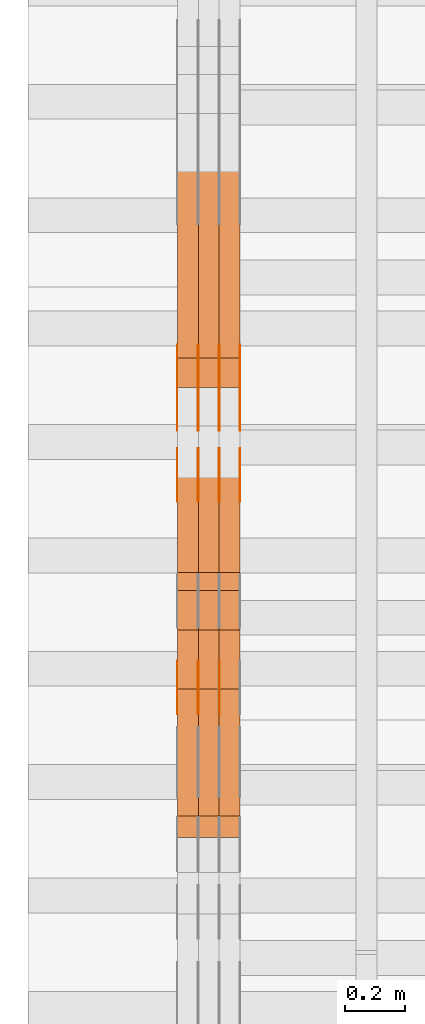
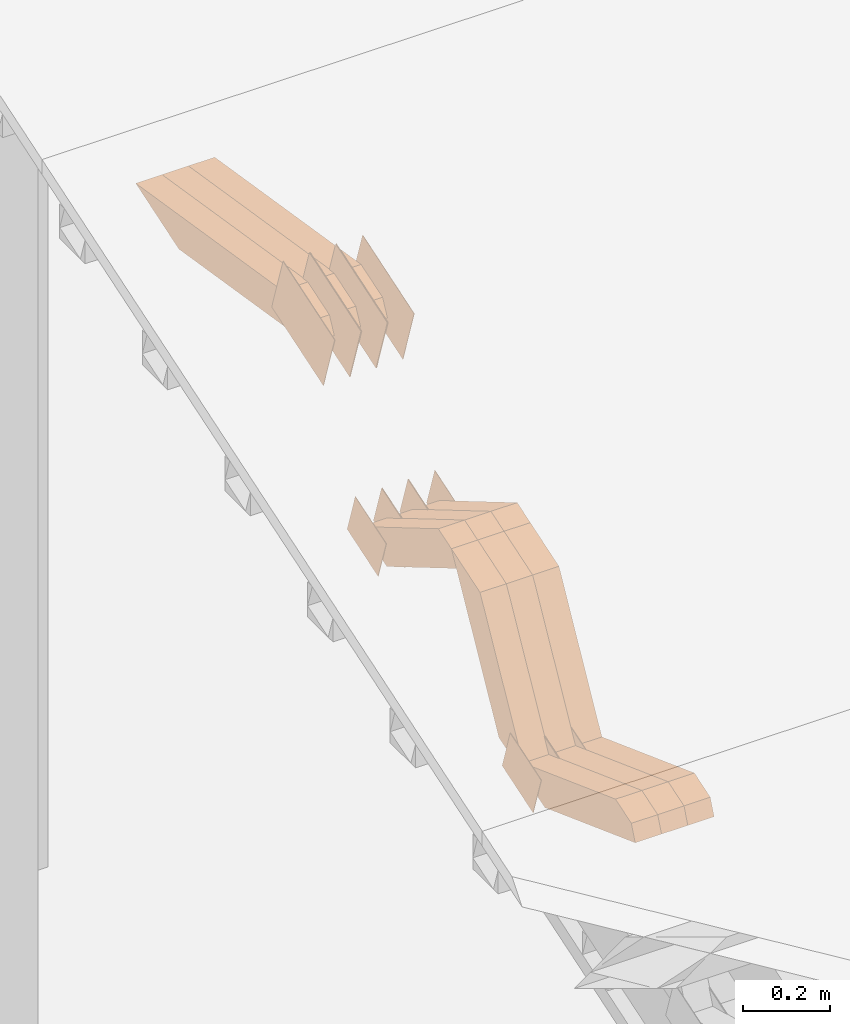
# One storey, part 47 of 385: 28 proxies.
"""IFC2X3 building model written with IfcOpenShell, lengths in millimetres."""

from ifc_helpers import new_model, entity, si_unit, converted_unit, derived_unit, direction, frame, origin, place, context, subcontext, project, spatial, polyline, outline, extrude, source, transform, mapped, material, type_object, type_shapes, element, save


model = new_model("IFC2X3")

# Units and contexts
model_context = context("Model", 3, precision=0.01, world=origin(), true_north=direction((6.12303176911189e-17, 1.0)))
body_context = subcontext(model_context, "Body", "Model", "MODEL_VIEW")
ifc_project = project(units=[si_unit("LENGTHUNIT", "METRE", prefix="MILLI"), si_unit("AREAUNIT", "SQUARE_METRE"), si_unit("VOLUMEUNIT", "CUBIC_METRE"), converted_unit("PLANEANGLEUNIT", "DEGREE", entity("IfcRatioMeasure", 0.0174532925199433), si_unit("PLANEANGLEUNIT", "RADIAN"), dimensions=[0, 0, 0, 0, 0, 0, 0]), si_unit("MASSUNIT", "GRAM", prefix="KILO"), derived_unit("MASSDENSITYUNIT", [(si_unit("MASSUNIT", "GRAM", prefix="KILO"), 1), (si_unit("LENGTHUNIT", "METRE"), -3)]), si_unit("TIMEUNIT", "SECOND"), si_unit("FREQUENCYUNIT", "HERTZ"), si_unit("THERMODYNAMICTEMPERATUREUNIT", "DEGREE_CELSIUS"), derived_unit("THERMALTRANSMITTANCEUNIT", [(si_unit("MASSUNIT", "GRAM", prefix="KILO"), 1), (si_unit("THERMODYNAMICTEMPERATUREUNIT", "KELVIN"), -1), (si_unit("TIMEUNIT", "SECOND"), -3)]), derived_unit("VOLUMETRICFLOWRATEUNIT", [(si_unit("LENGTHUNIT", "METRE"), 3), (si_unit("TIMEUNIT", "SECOND"), -1)]), si_unit("ELECTRICCURRENTUNIT", "AMPERE"), si_unit("ELECTRICVOLTAGEUNIT", "VOLT"), si_unit("POWERUNIT", "WATT"), si_unit("FORCEUNIT", "NEWTON", prefix="KILO"), si_unit("ILLUMINANCEUNIT", "LUX"), si_unit("LUMINOUSFLUXUNIT", "LUMEN"), si_unit("LUMINOUSINTENSITYUNIT", "CANDELA"), derived_unit("USERDEFINED", [(si_unit("MASSUNIT", "GRAM", prefix="KILO"), -1), (si_unit("LENGTHUNIT", "METRE"), -2), (si_unit("TIMEUNIT", "SECOND"), 3), (si_unit("LUMINOUSFLUXUNIT", "LUMEN"), 1)]), derived_unit("LINEARVELOCITYUNIT", [(si_unit("LENGTHUNIT", "METRE"), 1), (si_unit("TIMEUNIT", "SECOND"), -1)]), si_unit("PRESSUREUNIT", "PASCAL"), derived_unit("USERDEFINED", [(si_unit("LENGTHUNIT", "METRE"), -2), (si_unit("MASSUNIT", "GRAM", prefix="KILO"), 1), (si_unit("TIMEUNIT", "SECOND"), -2)])], contexts=[model_context])

# Site, building, storey
site_placement = place(None, origin())
site = spatial("IfcSite", under=ifc_project, at=site_placement, CompositionType="ELEMENT")
building_placement = place(site_placement, origin())
building = spatial("IfcBuilding", under=site, at=building_placement, CompositionType="ELEMENT")
storey_placement = place(building_placement, origin())
storey = spatial("IfcBuildingStorey", under=building, at=storey_placement, Name="Default", CompositionType="ELEMENT", Elevation=0.0)

# Proxies
ifc_material_1 = material(Name="IfcSurfaceStyle #37892")
building_element_proxy_type_1 = type_object("IfcBuildingElementProxyType", PredefinedType="NOTDEFINED", material=ifc_material_1)
shared_shape_1 = source(origin(), body_context, "Body", "SweptSolid", [
    extrude(outline(polyline([(-75.0008041947458, -59.9996998629349), (75.0007893252423, -59.9996998629349), (75.0008041947458, 59.9996998629349), (-75.0007893252423, 59.9996998629349), (-75.0008041947458, -59.9996998629349)])), frame((75.0008041947458, 60.0002282421692, 0.0), z_axis=(0.0, 0.0, 1.0), x_axis=(-1.0, 0.0, 0.0)), (0.0, 0.0, 1.0), 1.3),
])
type_shapes(building_element_proxy_type_1, [shared_shape_1])
proxy_1_placement = place(building_placement, frame((316.299999999986, 9291.048828125, 2194.94482421875), z_axis=(-1.0, 0.0, 0.0), x_axis=(0.0, 0.951056516295124, 0.309016994375039)))
element("IfcBuildingElementProxy", 1, at=proxy_1_placement, inside=storey, type_object=building_element_proxy_type_1, material=ifc_material_1, context=body_context, shape_type="MappedRepresentation", body=[
    mapped(shared_shape_1, transform((0.0, 0.0, 0.0), scale=1.0)),
])
ifc_material_2 = material(Name="IfcSurfaceStyle #37835")
building_element_proxy_type_2 = type_object("IfcBuildingElementProxyType", PredefinedType="NOTDEFINED", material=ifc_material_2)
shared_shape_2 = source(origin(), body_context, "Body", "SweptSolid", [
    extrude(outline(polyline([(-75.0008041947458, -59.9996998629349), (75.0007893252423, -59.9996998629349), (75.0008041947458, 59.9996998629349), (-75.0007893252423, 59.9996998629349), (-75.0008041947458, -59.9996998629349)])), frame((75.0008041947458, 60.0002282421692, 0.0), z_axis=(0.0, 0.0, 1.0), x_axis=(-1.0, 0.0, 0.0)), (0.0, 0.0, 1.0), 1.29999999999999),
])
type_shapes(building_element_proxy_type_2, [shared_shape_2])
proxy_2_placement = place(building_placement, frame((245.0, 9291.048828125, 2194.94482421875), z_axis=(-1.0, 0.0, 0.0), x_axis=(0.0, 0.951056516295124, 0.309016994375039)))
element("IfcBuildingElementProxy", 2, at=proxy_2_placement, inside=storey, type_object=building_element_proxy_type_2, material=ifc_material_2, context=body_context, shape_type="MappedRepresentation", body=[
    mapped(shared_shape_2, transform((0.0, 0.0, 0.0), scale=1.0)),
])
ifc_material_3 = material(Name="IfcSurfaceStyle #37778")
building_element_proxy_type_3 = type_object("IfcBuildingElementProxyType", PredefinedType="NOTDEFINED", material=ifc_material_3)
shared_shape_3 = source(origin(), body_context, "Body", "SweptSolid", [
    extrude(outline(polyline([(-75.0008041947458, -59.9996998629349), (75.0007893252423, -59.9996998629349), (75.0008041947458, 59.9996998629349), (-75.0007893252423, 59.9996998629349), (-75.0008041947458, -59.9996998629349)])), frame((75.0008041947458, 60.0002282421692, 0.0), z_axis=(0.0, 0.0, 1.0), x_axis=(-1.0, 0.0, 0.0)), (0.0, 0.0, 1.0), 1.29999999999999),
])
type_shapes(building_element_proxy_type_3, [shared_shape_3])
proxy_3_placement = place(building_placement, frame((246.299999999986, 9291.048828125, 2194.94482421875), z_axis=(-1.0, 0.0, 0.0), x_axis=(0.0, 0.951056516295124, 0.309016994375039)))
element("IfcBuildingElementProxy", 3, at=proxy_3_placement, inside=storey, type_object=building_element_proxy_type_3, material=ifc_material_3, context=body_context, shape_type="MappedRepresentation", body=[
    mapped(shared_shape_3, transform((0.0, 0.0, 0.0), scale=1.0)),
])
ifc_material_4 = material(Name="IfcSurfaceStyle #37721")
building_element_proxy_type_4 = type_object("IfcBuildingElementProxyType", PredefinedType="NOTDEFINED", material=ifc_material_4)
shared_shape_4 = source(origin(), body_context, "Body", "SweptSolid", [
    extrude(outline(polyline([(-75.0008041947458, -59.9996998629349), (75.0007893252423, -59.9996998629349), (75.0008041947458, 59.9996998629349), (-75.0007893252423, 59.9996998629349), (-75.0008041947458, -59.9996998629349)])), frame((75.0008041947458, 60.0002282421692, 0.0), z_axis=(0.0, 0.0, 1.0), x_axis=(-1.0, 0.0, 0.0)), (0.0, 0.0, 1.0), 1.29999999999999),
])
type_shapes(building_element_proxy_type_4, [shared_shape_4])
proxy_4_placement = place(building_placement, frame((175.0, 9291.048828125, 2194.94482421875), z_axis=(-1.0, 0.0, 0.0), x_axis=(0.0, 0.951056516295124, 0.309016994375039)))
element("IfcBuildingElementProxy", 4, at=proxy_4_placement, inside=storey, type_object=building_element_proxy_type_4, material=ifc_material_4, context=body_context, shape_type="MappedRepresentation", body=[
    mapped(shared_shape_4, transform((0.0, 0.0, 0.0), scale=1.0)),
])
ifc_material_5 = material(Name="IfcSurfaceStyle #37664")
building_element_proxy_type_5 = type_object("IfcBuildingElementProxyType", PredefinedType="NOTDEFINED", material=ifc_material_5)
shared_shape_5 = source(origin(), body_context, "Body", "SweptSolid", [
    extrude(outline(polyline([(-124.999432723313, -83.9999457831645), (125.000177551971, -83.9999457831645), (124.999395001513, 83.9999457831646), (-125.000139830171, 83.9999457831645), (-124.999432723313, -83.9999457831645)])), frame((125.000177551971, 84.0001194377192, 0.0), z_axis=(0.0, 0.0, 1.0), x_axis=(-1.0, 0.0, 0.0)), (0.0, 0.0, 1.0), 1.3),
])
type_shapes(building_element_proxy_type_5, [shared_shape_5])
proxy_5_placement = place(building_placement, frame((386.299999999986, 10242.0968435406, 2855.88278137571), z_axis=(-1.0, 0.0, 0.0), x_axis=(0.0, 0.951056516295154, 0.309016994374948)))
element("IfcBuildingElementProxy", 5, at=proxy_5_placement, inside=storey, type_object=building_element_proxy_type_5, material=ifc_material_5, context=body_context, shape_type="MappedRepresentation", body=[
    mapped(shared_shape_5, transform((0.0, 0.0, 0.0), scale=1.0)),
])
ifc_material_6 = material(Name="IfcSurfaceStyle #37607")
building_element_proxy_type_6 = type_object("IfcBuildingElementProxyType", PredefinedType="NOTDEFINED", material=ifc_material_6)
shared_shape_6 = source(origin(), body_context, "Body", "SweptSolid", [
    extrude(outline(polyline([(-124.999432723313, -83.9999457831645), (125.000177551971, -83.9999457831645), (124.999395001513, 83.9999457831646), (-125.000139830171, 83.9999457831645), (-124.999432723313, -83.9999457831645)])), frame((125.000177551971, 84.0001194377192, 0.0), z_axis=(0.0, 0.0, 1.0), x_axis=(-1.0, 0.0, 0.0)), (0.0, 0.0, 1.0), 1.3),
])
type_shapes(building_element_proxy_type_6, [shared_shape_6])
proxy_6_placement = place(building_placement, frame((315.0, 10242.0968435406, 2855.88278137571), z_axis=(-1.0, 0.0, 0.0), x_axis=(0.0, 0.951056516295154, 0.309016994374948)))
element("IfcBuildingElementProxy", 6, at=proxy_6_placement, inside=storey, type_object=building_element_proxy_type_6, material=ifc_material_6, context=body_context, shape_type="MappedRepresentation", body=[
    mapped(shared_shape_6, transform((0.0, 0.0, 0.0), scale=1.0)),
])
ifc_material_7 = material(Name="IfcSurfaceStyle #37550")
building_element_proxy_type_7 = type_object("IfcBuildingElementProxyType", PredefinedType="NOTDEFINED", material=ifc_material_7)
shared_shape_7 = source(origin(), body_context, "Body", "SweptSolid", [
    extrude(outline(polyline([(-124.999432723313, -83.9999457831645), (125.000177551971, -83.9999457831645), (124.999395001513, 83.9999457831646), (-125.000139830171, 83.9999457831645), (-124.999432723313, -83.9999457831645)])), frame((125.000177551971, 84.0001194377192, 0.0), z_axis=(0.0, 0.0, 1.0), x_axis=(-1.0, 0.0, 0.0)), (0.0, 0.0, 1.0), 1.3),
])
type_shapes(building_element_proxy_type_7, [shared_shape_7])
proxy_7_placement = place(building_placement, frame((316.299999999986, 10242.0968435406, 2855.88278137571), z_axis=(-1.0, 0.0, 0.0), x_axis=(0.0, 0.951056516295154, 0.309016994374948)))
element("IfcBuildingElementProxy", 7, at=proxy_7_placement, inside=storey, type_object=building_element_proxy_type_7, material=ifc_material_7, context=body_context, shape_type="MappedRepresentation", body=[
    mapped(shared_shape_7, transform((0.0, 0.0, 0.0), scale=1.0)),
])
ifc_material_8 = material(Name="IfcSurfaceStyle #37493")
building_element_proxy_type_8 = type_object("IfcBuildingElementProxyType", PredefinedType="NOTDEFINED", material=ifc_material_8)
shared_shape_8 = source(origin(), body_context, "Body", "SweptSolid", [
    extrude(outline(polyline([(-124.999432723313, -83.9999457831645), (125.000177551971, -83.9999457831645), (124.999395001513, 83.9999457831646), (-125.000139830171, 83.9999457831645), (-124.999432723313, -83.9999457831645)])), frame((125.000177551971, 84.0001194377192, 0.0), z_axis=(0.0, 0.0, 1.0), x_axis=(-1.0, 0.0, 0.0)), (0.0, 0.0, 1.0), 1.29999999999998),
])
type_shapes(building_element_proxy_type_8, [shared_shape_8])
proxy_8_placement = place(building_placement, frame((245.0, 10242.0968435406, 2855.88278137571), z_axis=(-1.0, 0.0, 0.0), x_axis=(0.0, 0.951056516295154, 0.309016994374948)))
element("IfcBuildingElementProxy", 8, at=proxy_8_placement, inside=storey, type_object=building_element_proxy_type_8, material=ifc_material_8, context=body_context, shape_type="MappedRepresentation", body=[
    mapped(shared_shape_8, transform((0.0, 0.0, 0.0), scale=1.0)),
])
ifc_material_9 = material(Name="IfcSurfaceStyle #37436")
building_element_proxy_type_9 = type_object("IfcBuildingElementProxyType", PredefinedType="NOTDEFINED", material=ifc_material_9)
shared_shape_9 = source(origin(), body_context, "Body", "SweptSolid", [
    extrude(outline(polyline([(-124.999432723313, -83.9999457831645), (125.000177551971, -83.9999457831645), (124.999395001513, 83.9999457831646), (-125.000139830171, 83.9999457831645), (-124.999432723313, -83.9999457831645)])), frame((125.000177551971, 84.0001194377192, 0.0), z_axis=(0.0, 0.0, 1.0), x_axis=(-1.0, 0.0, 0.0)), (0.0, 0.0, 1.0), 1.29999999999998),
])
type_shapes(building_element_proxy_type_9, [shared_shape_9])
proxy_9_placement = place(building_placement, frame((246.299999999986, 10242.0968435406, 2855.88278137571), z_axis=(-1.0, 0.0, 0.0), x_axis=(0.0, 0.951056516295154, 0.309016994374948)))
element("IfcBuildingElementProxy", 9, at=proxy_9_placement, inside=storey, type_object=building_element_proxy_type_9, material=ifc_material_9, context=body_context, shape_type="MappedRepresentation", body=[
    mapped(shared_shape_9, transform((0.0, 0.0, 0.0), scale=1.0)),
])
ifc_material_10 = material(Name="IfcSurfaceStyle #37379")
building_element_proxy_type_10 = type_object("IfcBuildingElementProxyType", PredefinedType="NOTDEFINED", material=ifc_material_10)
shared_shape_10 = source(origin(), body_context, "Body", "SweptSolid", [
    extrude(outline(polyline([(-124.999432723313, -83.9999457831645), (125.000177551971, -83.9999457831645), (124.999395001513, 83.9999457831646), (-125.000139830171, 83.9999457831645), (-124.999432723313, -83.9999457831645)])), frame((125.000177551971, 84.0001194377192, 0.0), z_axis=(0.0, 0.0, 1.0), x_axis=(-1.0, 0.0, 0.0)), (0.0, 0.0, 1.0), 1.29999999999998),
])
type_shapes(building_element_proxy_type_10, [shared_shape_10])
proxy_10_placement = place(building_placement, frame((175.0, 10242.0968435406, 2855.88278137571), z_axis=(-1.0, 0.0, 0.0), x_axis=(0.0, 0.951056516295154, 0.309016994374948)))
element("IfcBuildingElementProxy", 10, at=proxy_10_placement, inside=storey, type_object=building_element_proxy_type_10, material=ifc_material_10, context=body_context, shape_type="MappedRepresentation", body=[
    mapped(shared_shape_10, transform((0.0, 0.0, 0.0), scale=1.0)),
])
ifc_material_11 = material(Name="IfcSurfaceStyle #35954")
building_element_proxy_type_11 = type_object("IfcBuildingElementProxyType", PredefinedType="NOTDEFINED", material=ifc_material_11)
shared_shape_11 = source(origin(), body_context, "Body", "SweptSolid", [
    extrude(outline(polyline([(-74.9998754286189, -60.0000016373433), (74.9998605591118, -60.0000016373433), (74.9998754286189, 60.0000016373433), (-74.9998605591118, 60.0000016373433), (-74.9998754286189, -60.0000016373433)])), frame((74.9999131819004, 60.0000016373433, 0.0), z_axis=(0.0, 0.0, 1.0), x_axis=(-1.0, 0.0, 0.0)), (0.0, 0.0, 1.0), 1.3),
])
type_shapes(building_element_proxy_type_11, [shared_shape_11])
proxy_11_placement = place(building_placement, frame((386.299999999986, 10004.8612689908, 2426.87628052724), z_axis=(-1.0, 0.0, 0.0), x_axis=(0.0, 0.951056516295124, 0.309016994375039)))
element("IfcBuildingElementProxy", 11, at=proxy_11_placement, inside=storey, type_object=building_element_proxy_type_11, material=ifc_material_11, context=body_context, shape_type="MappedRepresentation", body=[
    mapped(shared_shape_11, transform((0.0, 0.0, 0.0), scale=1.0)),
])
ifc_material_12 = material(Name="IfcSurfaceStyle #35897")
building_element_proxy_type_12 = type_object("IfcBuildingElementProxyType", PredefinedType="NOTDEFINED", material=ifc_material_12)
shared_shape_12 = source(origin(), body_context, "Body", "SweptSolid", [
    extrude(outline(polyline([(-74.9998754286189, -60.0000016373433), (74.9998605591118, -60.0000016373433), (74.9998754286189, 60.0000016373433), (-74.9998605591118, 60.0000016373433), (-74.9998754286189, -60.0000016373433)])), frame((74.9999131819004, 60.0000016373433, 0.0), z_axis=(0.0, 0.0, 1.0), x_axis=(-1.0, 0.0, 0.0)), (0.0, 0.0, 1.0), 1.3),
])
type_shapes(building_element_proxy_type_12, [shared_shape_12])
proxy_12_placement = place(building_placement, frame((315.0, 10004.8612689908, 2426.87628052724), z_axis=(-1.0, 0.0, 0.0), x_axis=(0.0, 0.951056516295124, 0.309016994375039)))
element("IfcBuildingElementProxy", 12, at=proxy_12_placement, inside=storey, type_object=building_element_proxy_type_12, material=ifc_material_12, context=body_context, shape_type="MappedRepresentation", body=[
    mapped(shared_shape_12, transform((0.0, 0.0, 0.0), scale=1.0)),
])
ifc_material_13 = material(Name="IfcSurfaceStyle #35840")
building_element_proxy_type_13 = type_object("IfcBuildingElementProxyType", PredefinedType="NOTDEFINED", material=ifc_material_13)
shared_shape_13 = source(origin(), body_context, "Body", "SweptSolid", [
    extrude(outline(polyline([(-74.9998754286189, -60.0000016373433), (74.9998605591118, -60.0000016373433), (74.9998754286189, 60.0000016373433), (-74.9998605591118, 60.0000016373433), (-74.9998754286189, -60.0000016373433)])), frame((74.9999131819004, 60.0000016373433, 0.0), z_axis=(0.0, 0.0, 1.0), x_axis=(-1.0, 0.0, 0.0)), (0.0, 0.0, 1.0), 1.3),
])
type_shapes(building_element_proxy_type_13, [shared_shape_13])
proxy_13_placement = place(building_placement, frame((316.299999999986, 10004.8612689908, 2426.87628052724), z_axis=(-1.0, 0.0, 0.0), x_axis=(0.0, 0.951056516295124, 0.309016994375039)))
element("IfcBuildingElementProxy", 13, at=proxy_13_placement, inside=storey, type_object=building_element_proxy_type_13, material=ifc_material_13, context=body_context, shape_type="MappedRepresentation", body=[
    mapped(shared_shape_13, transform((0.0, 0.0, 0.0), scale=1.0)),
])
ifc_material_14 = material(Name="IfcSurfaceStyle #35783")
building_element_proxy_type_14 = type_object("IfcBuildingElementProxyType", PredefinedType="NOTDEFINED", material=ifc_material_14)
shared_shape_14 = source(origin(), body_context, "Body", "SweptSolid", [
    extrude(outline(polyline([(-74.9998754286189, -60.0000016373433), (74.9998605591118, -60.0000016373433), (74.9998754286189, 60.0000016373433), (-74.9998605591118, 60.0000016373433), (-74.9998754286189, -60.0000016373433)])), frame((74.9999131819004, 60.0000016373433, 0.0), z_axis=(0.0, 0.0, 1.0), x_axis=(-1.0, 0.0, 0.0)), (0.0, 0.0, 1.0), 1.29999999999999),
])
type_shapes(building_element_proxy_type_14, [shared_shape_14])
proxy_14_placement = place(building_placement, frame((245.0, 10004.8612689908, 2426.87628052724), z_axis=(-1.0, 0.0, 0.0), x_axis=(0.0, 0.951056516295124, 0.309016994375039)))
element("IfcBuildingElementProxy", 14, at=proxy_14_placement, inside=storey, type_object=building_element_proxy_type_14, material=ifc_material_14, context=body_context, shape_type="MappedRepresentation", body=[
    mapped(shared_shape_14, transform((0.0, 0.0, 0.0), scale=1.0)),
])
ifc_material_15 = material(Name="IfcSurfaceStyle #35726")
building_element_proxy_type_15 = type_object("IfcBuildingElementProxyType", PredefinedType="NOTDEFINED", material=ifc_material_15)
shared_shape_15 = source(origin(), body_context, "Body", "SweptSolid", [
    extrude(outline(polyline([(-74.9998754286189, -60.0000016373433), (74.9998605591118, -60.0000016373433), (74.9998754286189, 60.0000016373433), (-74.9998605591118, 60.0000016373433), (-74.9998754286189, -60.0000016373433)])), frame((74.9999131819004, 60.0000016373433, 0.0), z_axis=(0.0, 0.0, 1.0), x_axis=(-1.0, 0.0, 0.0)), (0.0, 0.0, 1.0), 1.29999999999999),
])
type_shapes(building_element_proxy_type_15, [shared_shape_15])
proxy_15_placement = place(building_placement, frame((246.299999999986, 10004.8612689908, 2426.87628052724), z_axis=(-1.0, 0.0, 0.0), x_axis=(0.0, 0.951056516295124, 0.309016994375039)))
element("IfcBuildingElementProxy", 15, at=proxy_15_placement, inside=storey, type_object=building_element_proxy_type_15, material=ifc_material_15, context=body_context, shape_type="MappedRepresentation", body=[
    mapped(shared_shape_15, transform((0.0, 0.0, 0.0), scale=1.0)),
])
ifc_material_16 = material(Name="IfcSurfaceStyle #35669")
building_element_proxy_type_16 = type_object("IfcBuildingElementProxyType", PredefinedType="NOTDEFINED", material=ifc_material_16)
shared_shape_16 = source(origin(), body_context, "Body", "SweptSolid", [
    extrude(outline(polyline([(-74.9998754286189, -60.0000016373433), (74.9998605591118, -60.0000016373433), (74.9998754286189, 60.0000016373433), (-74.9998605591118, 60.0000016373433), (-74.9998754286189, -60.0000016373433)])), frame((74.9999131819004, 60.0000016373433, 0.0), z_axis=(0.0, 0.0, 1.0), x_axis=(-1.0, 0.0, 0.0)), (0.0, 0.0, 1.0), 1.29999999999999),
])
type_shapes(building_element_proxy_type_16, [shared_shape_16])
proxy_16_placement = place(building_placement, frame((175.0, 10004.8612689908, 2426.87628052724), z_axis=(-1.0, 0.0, 0.0), x_axis=(0.0, 0.951056516295124, 0.309016994375039)))
element("IfcBuildingElementProxy", 16, at=proxy_16_placement, inside=storey, type_object=building_element_proxy_type_16, material=ifc_material_16, context=body_context, shape_type="MappedRepresentation", body=[
    mapped(shared_shape_16, transform((0.0, 0.0, 0.0), scale=1.0)),
])
ifc_material_17 = material(Name="IfcSurfaceStyle #15632")
building_element_proxy_type_17 = type_object("IfcBuildingElementProxyType", Name="T1-W5 15630", PredefinedType="NOTDEFINED", material=ifc_material_17)
shared_shape_17 = source(origin(), body_context, "Body", "SweptSolid", [
    extrude(outline(polyline([(-301.214270081322, -47.5000783565111), (303.980395954293, -47.5000783565111), (288.664123931657, 0.000197935560590153), (195.704076557203, 47.4999793887309), (-487.134326361831, 47.4999793887309), (-301.214270081322, -47.5000783565111)])), frame((303.980395954293, 47.5001815410909, 0.0), z_axis=(0.0, 0.0, 1.0), x_axis=(-1.0, 0.0, 0.0)), (0.0, 0.0, 1.0), 70.0),
])
type_shapes(building_element_proxy_type_17, [shared_shape_17])
proxy_17_placement = place(building_placement, frame((385.0, 10379.2051671398, 2863.91176079486), z_axis=(-1.0, 0.0, 0.0), x_axis=(0.0, 0.987508363398486, -0.1575665961365)))
element("IfcBuildingElementProxy", 17, at=proxy_17_placement, inside=storey, type_object=building_element_proxy_type_17, material=ifc_material_17, Name="T1-W5", context=body_context, shape_type="MappedRepresentation", body=[
    mapped(shared_shape_17, transform((0.0, 0.0, 0.0), scale=1.0)),
])
ifc_material_18 = material(Name="IfcSurfaceStyle #15566")
building_element_proxy_type_18 = type_object("IfcBuildingElementProxyType", Name="T1-W5 15564", PredefinedType="NOTDEFINED", material=ifc_material_18)
shared_shape_18 = source(origin(), body_context, "Body", "SweptSolid", [
    extrude(outline(polyline([(-301.214270081322, -47.5000783565111), (303.980395954293, -47.5000783565111), (288.664123931657, 0.000197935560590153), (195.704076557203, 47.4999793887309), (-487.134326361831, 47.4999793887309), (-301.214270081322, -47.5000783565111)])), frame((303.980395954293, 47.5001815410909, 0.0), z_axis=(0.0, 0.0, 1.0), x_axis=(-1.0, 0.0, 0.0)), (0.0, 0.0, 1.0), 70.0),
])
type_shapes(building_element_proxy_type_18, [shared_shape_18])
proxy_18_placement = place(building_placement, frame((315.0, 10379.2051671398, 2863.91176079486), z_axis=(-1.0, 0.0, 0.0), x_axis=(0.0, 0.987508363398486, -0.1575665961365)))
element("IfcBuildingElementProxy", 18, at=proxy_18_placement, inside=storey, type_object=building_element_proxy_type_18, material=ifc_material_18, Name="T1-W5", context=body_context, shape_type="MappedRepresentation", body=[
    mapped(shared_shape_18, transform((0.0, 0.0, 0.0), scale=1.0)),
])
ifc_material_19 = material(Name="IfcSurfaceStyle #15500")
building_element_proxy_type_19 = type_object("IfcBuildingElementProxyType", Name="T1-W5 15498", PredefinedType="NOTDEFINED", material=ifc_material_19)
shared_shape_19 = source(origin(), body_context, "Body", "SweptSolid", [
    extrude(outline(polyline([(-301.214270081322, -47.5000783565111), (303.980395954293, -47.5000783565111), (288.664123931657, 0.000197935560590153), (195.704076557203, 47.4999793887309), (-487.134326361831, 47.4999793887309), (-301.214270081322, -47.5000783565111)])), frame((303.980395954293, 47.5001815410909, 0.0), z_axis=(0.0, 0.0, 1.0), x_axis=(-1.0, 0.0, 0.0)), (0.0, 0.0, 1.0), 70.0),
])
type_shapes(building_element_proxy_type_19, [shared_shape_19])
proxy_19_placement = place(building_placement, frame((245.0, 10379.2051671398, 2863.91176079486), z_axis=(-1.0, 0.0, 0.0), x_axis=(0.0, 0.987508363398486, -0.1575665961365)))
element("IfcBuildingElementProxy", 19, at=proxy_19_placement, inside=storey, type_object=building_element_proxy_type_19, material=ifc_material_19, Name="T1-W5", context=body_context, shape_type="MappedRepresentation", body=[
    mapped(shared_shape_19, transform((0.0, 0.0, 0.0), scale=1.0)),
])
ifc_material_20 = material(Name="IfcSurfaceStyle #14840")
building_element_proxy_type_20 = type_object("IfcBuildingElementProxyType", Name="T1-W43 14838", PredefinedType="NOTDEFINED", material=ifc_material_20)
shared_shape_20 = source(origin(), body_context, "Body", "SweptSolid", [
    extrude(outline(polyline([(-198.159905426436, -47.4999961988362), (173.155878681738, -47.4999961988362), (174.585865234707, -0.00038778214839239), (132.582704932703, 47.5001900899104), (-282.164543422712, 47.5001900899104), (-198.159905426436, -47.4999961988362)])), frame((174.585865234707, 47.5001900899104, 0.0), z_axis=(0.0, 0.0, 1.0), x_axis=(-1.0, 0.0, 0.0)), (0.0, 0.0, 1.0), 70.0),
])
type_shapes(building_element_proxy_type_20, [shared_shape_20])
proxy_20_placement = place(building_placement, frame((385.0, 9730.71877771152, 2634.4881681647), z_axis=(-1.0, 0.0, 0.0), x_axis=(0.0, 0.861495156633645, -0.507765787639115)))
element("IfcBuildingElementProxy", 20, at=proxy_20_placement, inside=storey, type_object=building_element_proxy_type_20, material=ifc_material_20, Name="T1-W43", context=body_context, shape_type="MappedRepresentation", body=[
    mapped(shared_shape_20, transform((0.0, 0.0, 0.0), scale=1.0)),
])
ifc_material_21 = material(Name="IfcSurfaceStyle #14774")
building_element_proxy_type_21 = type_object("IfcBuildingElementProxyType", Name="T1-W43 14772", PredefinedType="NOTDEFINED", material=ifc_material_21)
shared_shape_21 = source(origin(), body_context, "Body", "SweptSolid", [
    extrude(outline(polyline([(-198.159905426436, -47.4999961988362), (173.155878681738, -47.4999961988362), (174.585865234707, -0.00038778214839239), (132.582704932703, 47.5001900899104), (-282.164543422712, 47.5001900899104), (-198.159905426436, -47.4999961988362)])), frame((174.585865234707, 47.5001900899104, 0.0), z_axis=(0.0, 0.0, 1.0), x_axis=(-1.0, 0.0, 0.0)), (0.0, 0.0, 1.0), 70.0),
])
type_shapes(building_element_proxy_type_21, [shared_shape_21])
proxy_21_placement = place(building_placement, frame((315.0, 9730.71877771152, 2634.4881681647), z_axis=(-1.0, 0.0, 0.0), x_axis=(0.0, 0.861495156633645, -0.507765787639115)))
element("IfcBuildingElementProxy", 21, at=proxy_21_placement, inside=storey, type_object=building_element_proxy_type_21, material=ifc_material_21, Name="T1-W43", context=body_context, shape_type="MappedRepresentation", body=[
    mapped(shared_shape_21, transform((0.0, 0.0, 0.0), scale=1.0)),
])
ifc_material_22 = material(Name="IfcSurfaceStyle #14708")
building_element_proxy_type_22 = type_object("IfcBuildingElementProxyType", Name="T1-W43 14706", PredefinedType="NOTDEFINED", material=ifc_material_22)
shared_shape_22 = source(origin(), body_context, "Body", "SweptSolid", [
    extrude(outline(polyline([(-198.159905426436, -47.4999961988362), (173.155878681738, -47.4999961988362), (174.585865234707, -0.00038778214839239), (132.582704932703, 47.5001900899104), (-282.164543422712, 47.5001900899104), (-198.159905426436, -47.4999961988362)])), frame((174.585865234707, 47.5001900899104, 0.0), z_axis=(0.0, 0.0, 1.0), x_axis=(-1.0, 0.0, 0.0)), (0.0, 0.0, 1.0), 70.0),
])
type_shapes(building_element_proxy_type_22, [shared_shape_22])
proxy_22_placement = place(building_placement, frame((245.0, 9730.71877771152, 2634.4881681647), z_axis=(-1.0, 0.0, 0.0), x_axis=(0.0, 0.861495156633645, -0.507765787639115)))
element("IfcBuildingElementProxy", 22, at=proxy_22_placement, inside=storey, type_object=building_element_proxy_type_22, material=ifc_material_22, Name="T1-W43", context=body_context, shape_type="MappedRepresentation", body=[
    mapped(shared_shape_22, transform((0.0, 0.0, 0.0), scale=1.0)),
])
ifc_material_23 = material(Name="IfcSurfaceStyle #14444")
building_element_proxy_type_23 = type_object("IfcBuildingElementProxyType", Name="T1-W33 14442", PredefinedType="NOTDEFINED", material=ifc_material_23)
shared_shape_23 = source(origin(), body_context, "Body", "SweptSolid", [
    extrude(outline(polyline([(-314.173070820175, -47.4997758466969), (139.635944117881, -47.4997758466969), (190.204920608233, 0.000348187720347082), (197.369205310989, 47.5001702328475), (-213.036999216928, 47.4990332728259), (-314.173070820175, -47.4997758466969)])), frame((197.369205310989, 47.5001702328475, 0.0), z_axis=(0.0, 0.0, 1.0), x_axis=(-1.0, 0.0, 0.0)), (0.0, 0.0, 1.0), 70.0),
])
type_shapes(building_element_proxy_type_23, [shared_shape_23])
proxy_23_placement = place(building_placement, frame((385.0, 9376.96875, 2191.01977539063), z_axis=(-1.0, 0.0, 0.0), x_axis=(0.0, 0.481632628948835, 0.876373214293907)))
element("IfcBuildingElementProxy", 23, at=proxy_23_placement, inside=storey, type_object=building_element_proxy_type_23, material=ifc_material_23, Name="T1-W33", context=body_context, shape_type="MappedRepresentation", body=[
    mapped(shared_shape_23, transform((0.0, 0.0, 0.0), scale=1.0)),
])
ifc_material_24 = material(Name="IfcSurfaceStyle #14378")
building_element_proxy_type_24 = type_object("IfcBuildingElementProxyType", Name="T1-W33 14376", PredefinedType="NOTDEFINED", material=ifc_material_24)
shared_shape_24 = source(origin(), body_context, "Body", "SweptSolid", [
    extrude(outline(polyline([(-314.173070820175, -47.4997758466969), (139.635944117881, -47.4997758466969), (190.204920608233, 0.000348187720347082), (197.369205310989, 47.5001702328475), (-213.036999216928, 47.4990332728259), (-314.173070820175, -47.4997758466969)])), frame((197.369205310989, 47.5001702328475, 0.0), z_axis=(0.0, 0.0, 1.0), x_axis=(-1.0, 0.0, 0.0)), (0.0, 0.0, 1.0), 70.0),
])
type_shapes(building_element_proxy_type_24, [shared_shape_24])
proxy_24_placement = place(building_placement, frame((315.0, 9376.96875, 2191.01977539063), z_axis=(-1.0, 0.0, 0.0), x_axis=(0.0, 0.481632628948835, 0.876373214293907)))
element("IfcBuildingElementProxy", 24, at=proxy_24_placement, inside=storey, type_object=building_element_proxy_type_24, material=ifc_material_24, Name="T1-W33", context=body_context, shape_type="MappedRepresentation", body=[
    mapped(shared_shape_24, transform((0.0, 0.0, 0.0), scale=1.0)),
])
ifc_material_25 = material(Name="IfcSurfaceStyle #14312")
building_element_proxy_type_25 = type_object("IfcBuildingElementProxyType", Name="T1-W33 14310", PredefinedType="NOTDEFINED", material=ifc_material_25)
shared_shape_25 = source(origin(), body_context, "Body", "SweptSolid", [
    extrude(outline(polyline([(-314.173070820175, -47.4997758466969), (139.635944117881, -47.4997758466969), (190.204920608233, 0.000348187720347082), (197.369205310989, 47.5001702328475), (-213.036999216928, 47.4990332728259), (-314.173070820175, -47.4997758466969)])), frame((197.369205310989, 47.5001702328475, 0.0), z_axis=(0.0, 0.0, 1.0), x_axis=(-1.0, 0.0, 0.0)), (0.0, 0.0, 1.0), 70.0),
])
type_shapes(building_element_proxy_type_25, [shared_shape_25])
proxy_25_placement = place(building_placement, frame((245.0, 9376.96875, 2191.01977539063), z_axis=(-1.0, 0.0, 0.0), x_axis=(0.0, 0.481632628948835, 0.876373214293907)))
element("IfcBuildingElementProxy", 25, at=proxy_25_placement, inside=storey, type_object=building_element_proxy_type_25, material=ifc_material_25, Name="T1-W33", context=body_context, shape_type="MappedRepresentation", body=[
    mapped(shared_shape_25, transform((0.0, 0.0, 0.0), scale=1.0)),
])
ifc_material_26 = material(Name="IfcSurfaceStyle #14048")
building_element_proxy_type_26 = type_object("IfcBuildingElementProxyType", Name="T1-W25 14046", PredefinedType="NOTDEFINED", material=ifc_material_26)
shared_shape_26 = source(origin(), body_context, "Body", "SweptSolid", [
    extrude(outline(polyline([(-229.232772462784, -47.5001671709529), (214.075939394384, -47.5001671709529), (212.688957821661, -0.000141058964427199), (152.358910178478, 47.5002377004352), (-349.891034931738, 47.5002377004352), (-229.232772462784, -47.5001671709529)])), frame((214.075939394384, 47.5002377004352, 0.0), z_axis=(0.0, 0.0, 1.0), x_axis=(-1.0, 0.0, 0.0)), (0.0, 0.0, 1.0), 70.0),
])
type_shapes(building_element_proxy_type_26, [shared_shape_26])
proxy_26_placement = place(building_placement, frame((385.0, 8892.81895960242, 2369.29665807578), z_axis=(-1.0, 0.0, 0.0), x_axis=(0.0, 0.938402514401222, -0.345544094097213)))
element("IfcBuildingElementProxy", 26, at=proxy_26_placement, inside=storey, type_object=building_element_proxy_type_26, material=ifc_material_26, Name="T1-W25", context=body_context, shape_type="MappedRepresentation", body=[
    mapped(shared_shape_26, transform((0.0, 0.0, 0.0), scale=1.0)),
])
ifc_material_27 = material(Name="IfcSurfaceStyle #13982")
building_element_proxy_type_27 = type_object("IfcBuildingElementProxyType", Name="T1-W25 13980", PredefinedType="NOTDEFINED", material=ifc_material_27)
shared_shape_27 = source(origin(), body_context, "Body", "SweptSolid", [
    extrude(outline(polyline([(-229.232772462784, -47.5001671709529), (214.075939394384, -47.5001671709529), (212.688957821661, -0.000141058964427199), (152.358910178478, 47.5002377004352), (-349.891034931738, 47.5002377004352), (-229.232772462784, -47.5001671709529)])), frame((214.075939394384, 47.5002377004352, 0.0), z_axis=(0.0, 0.0, 1.0), x_axis=(-1.0, 0.0, 0.0)), (0.0, 0.0, 1.0), 70.0),
])
type_shapes(building_element_proxy_type_27, [shared_shape_27])
proxy_27_placement = place(building_placement, frame((315.0, 8892.81895960242, 2369.29665807578), z_axis=(-1.0, 0.0, 0.0), x_axis=(0.0, 0.938402514401222, -0.345544094097213)))
element("IfcBuildingElementProxy", 27, at=proxy_27_placement, inside=storey, type_object=building_element_proxy_type_27, material=ifc_material_27, Name="T1-W25", context=body_context, shape_type="MappedRepresentation", body=[
    mapped(shared_shape_27, transform((0.0, 0.0, 0.0), scale=1.0)),
])
ifc_material_28 = material(Name="IfcSurfaceStyle #13916")
building_element_proxy_type_28 = type_object("IfcBuildingElementProxyType", Name="T1-W25 13914", PredefinedType="NOTDEFINED", material=ifc_material_28)
shared_shape_28 = source(origin(), body_context, "Body", "SweptSolid", [
    extrude(outline(polyline([(-229.232772462784, -47.5001671709529), (214.075939394384, -47.5001671709529), (212.688957821661, -0.000141058964427199), (152.358910178478, 47.5002377004352), (-349.891034931738, 47.5002377004352), (-229.232772462784, -47.5001671709529)])), frame((214.075939394384, 47.5002377004352, 0.0), z_axis=(0.0, 0.0, 1.0), x_axis=(-1.0, 0.0, 0.0)), (0.0, 0.0, 1.0), 70.0),
])
type_shapes(building_element_proxy_type_28, [shared_shape_28])
proxy_28_placement = place(building_placement, frame((245.0, 8892.81895960242, 2369.29665807578), z_axis=(-1.0, 0.0, 0.0), x_axis=(0.0, 0.938402514401222, -0.345544094097213)))
element("IfcBuildingElementProxy", 28, at=proxy_28_placement, inside=storey, type_object=building_element_proxy_type_28, material=ifc_material_28, Name="T1-W25", context=body_context, shape_type="MappedRepresentation", body=[
    mapped(shared_shape_28, transform((0.0, 0.0, 0.0), scale=1.0)),
])

save(model, "model.ifc")
